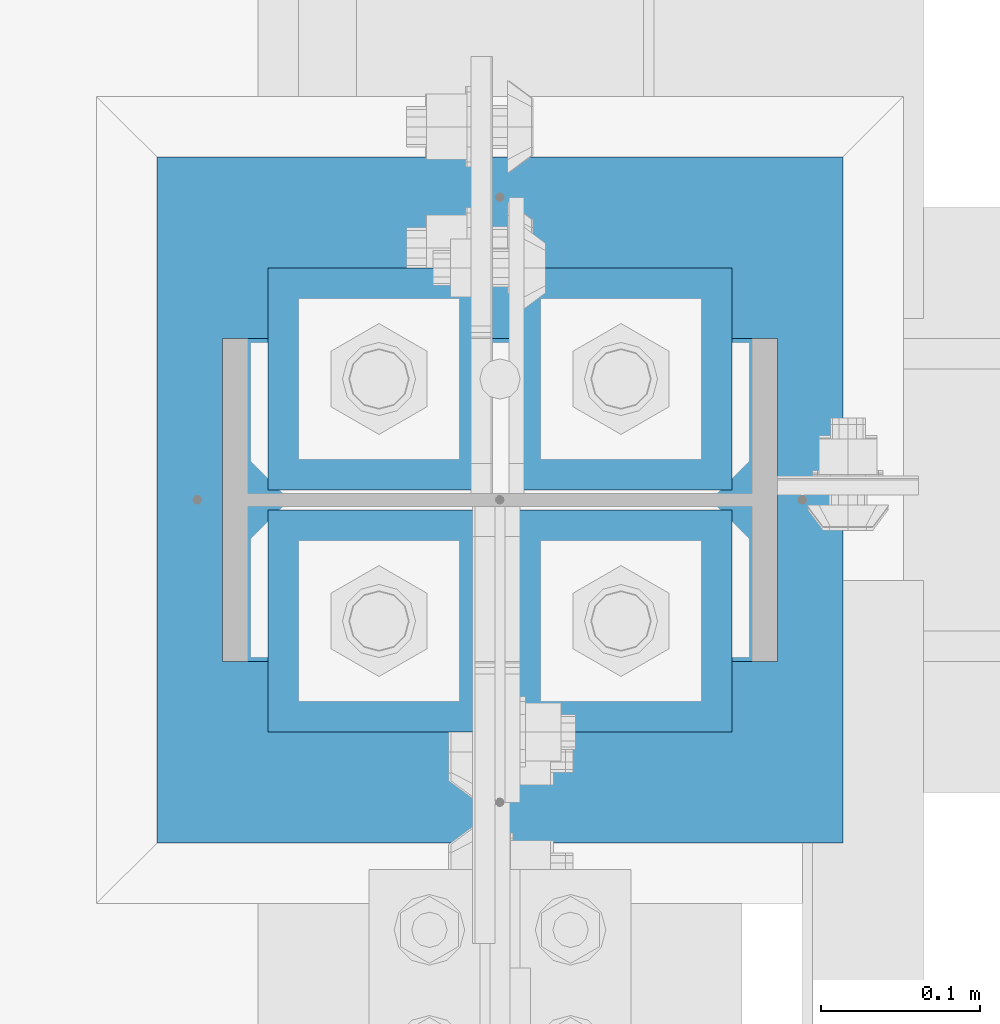
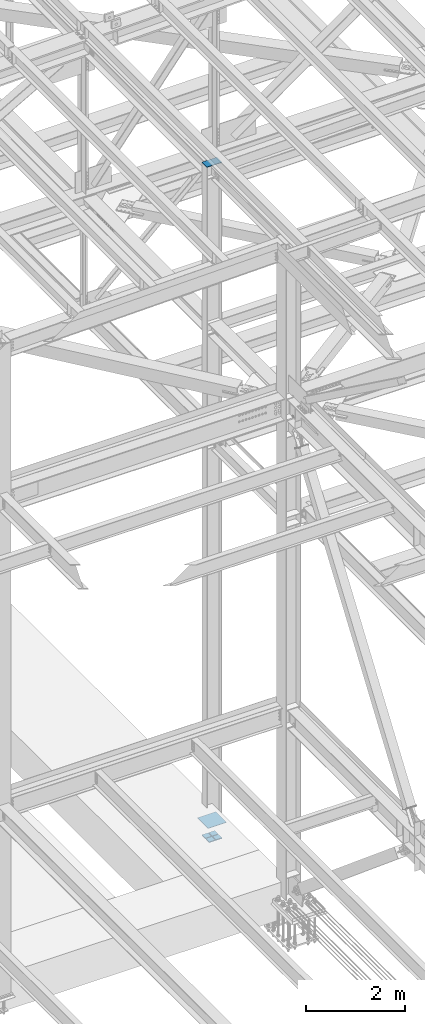
# One storey, part 2173 of 3843: 6 beams, 2 elements without a shape of their own.
"""IFC2X3 building model written with IfcOpenShell, lengths in millimetres."""

from ifc_helpers import new_model, si_unit, frame, origin_with_axes, place, context, subcontext, project, spatial, faceted_brep, material, type_object, element, aggregate, save


model = new_model("IFC2X3")

# Units and contexts
model_context = context("Model", 3, precision=1e-05, world=origin_with_axes())
body_context = subcontext(model_context, "Body", "Model", "MODEL_VIEW")
ifc_project = project(units=[si_unit("LENGTHUNIT", "METRE", prefix="MILLI"), si_unit("AREAUNIT", "SQUARE_METRE"), si_unit("VOLUMEUNIT", "CUBIC_METRE"), si_unit("MASSUNIT", "GRAM", prefix="KILO"), si_unit("TIMEUNIT", "SECOND"), si_unit("PLANEANGLEUNIT", "RADIAN"), si_unit("SOLIDANGLEUNIT", "STERADIAN"), si_unit("THERMODYNAMICTEMPERATUREUNIT", "DEGREE_CELSIUS"), si_unit("LUMINOUSINTENSITYUNIT", "LUMEN")], contexts=[model_context])

# Site, building, storey
site_placement = place(None, origin_with_axes())
site = spatial("IfcSite", under=ifc_project, at=site_placement, CompositionType="ELEMENT")
building_placement = place(site_placement, origin_with_axes())
building = spatial("IfcBuilding", under=site, at=building_placement, Name="Undefined", CompositionType="ELEMENT")
storey_placement = place(building_placement, origin_with_axes())
storey = spatial("IfcBuildingStorey", under=building, at=storey_placement, Name="Undefined", CompositionType="ELEMENT", Elevation=0.0)

# Assembly, beam
assembly_1_placement = place(storey_placement, origin_with_axes())
assembly_1 = element("IfcElementAssembly", 1, at=assembly_1_placement, inside=storey, Name="COLUMN", AssemblyPlace="NOTDEFINED", PredefinedType="RIGID_FRAME")
ifc_material = material(Name="STEEL/A572-50")
beam_type_1 = type_object("IfcBeamType", PredefinedType="NOTDEFINED")
beam_1_placement = place(assembly_1_placement, frame((77187.425, 28714.7, 46248.4455351929), z_axis=(0.0, 1.0, 0.0), x_axis=(-1.0, 0.0, 0.0)))
beam_1 = element("IfcBeam", 2, at=beam_1_placement, type_object=beam_type_1, material=ifc_material, Name="PLATE", context=body_context, shape_type="Brep", body=[
    faceted_brep([(1.74622982740402e-10, 6.35000000000582, -101.600000000195), (-1.67347025126219e-10, 6.35000000000582, 101.600000000151), (349.25, 6.34999999999854, 101.600000000006), (349.25, 6.34999999999854, -101.600000000006), (-1.67347025126219e-10, -6.35000000000582, 101.600000000151), (349.25, -6.34999999999854, 101.600000000006), (1.74622982740402e-10, -6.35000000000582, -101.600000000195), (349.25, -6.34999999999854, -101.600000000006)], [[[0, 1, 2, 3]], [[1, 4, 5, 2]], [[4, 6, 7, 5]], [[6, 0, 3, 7]], [[5, 7, 3, 2]], [[6, 4, 1, 0]]]),
])
aggregate(assembly_1, [beam_1])

# Assembly, beams
assembly_2_placement = place(storey_placement, origin_with_axes())
assembly_2 = element("IfcElementAssembly", 3, at=assembly_2_placement, inside=storey, Name="TEMPLATE", AssemblyPlace="NOTDEFINED", PredefinedType="RIGID_FRAME")
beam_type_2 = type_object("IfcBeamType", PredefinedType="NOTDEFINED")
beam_2_placement = place(assembly_2_placement, frame((77158.85, 28638.5, 29656.0875), z_axis=(0.0, 1.0, 0.0), x_axis=(-1.0, 0.0, 0.0)))
beam_2 = element("IfcBeam", 4, at=beam_2_placement, type_object=beam_type_2, material=ifc_material, context=body_context, shape_type="Brep", body=[
    faceted_brep([(0.0, 11.1124999999993, -69.8499999999985), (0.0, 11.1124999999993, 69.8499999999985), (139.699999999997, 11.1124999999993, 69.8499999999985), (139.699999999997, 11.1124999999993, -69.8499999999985), (0.0, -11.1124999999993, 69.8499999999985), (139.699999999997, -11.1124999999993, 69.8499999999985), (0.0, -11.1124999999993, -69.8499999999985), (139.699999999997, -11.1124999999993, -69.8499999999985)], [[[0, 1, 2, 3]], [[1, 4, 5, 2]], [[4, 6, 7, 5]], [[6, 0, 3, 7]], [[5, 7, 3, 2]], [[6, 4, 1, 0]]]),
])
beam_3_placement = place(assembly_2_placement, frame((77158.85, 28790.9, 29656.0875), z_axis=(0.0, 1.0, 0.0), x_axis=(-1.0, 0.0, 0.0)))
beam_3 = element("IfcBeam", 5, at=beam_3_placement, type_object=beam_type_2, material=ifc_material, context=body_context, shape_type="Brep", body=[
    faceted_brep([(0.0, 11.1124999999993, -69.8499999999985), (0.0, 11.1124999999993, 69.8499999999985), (139.699999999997, 11.1124999999993, 69.8499999999985), (139.699999999997, 11.1124999999993, -69.8499999999985), (0.0, -11.1124999999993, 69.8499999999985), (139.699999999997, -11.1124999999993, 69.8499999999985), (0.0, -11.1124999999993, -69.8499999999985), (139.699999999997, -11.1124999999993, -69.8499999999985)], [[[0, 1, 2, 3]], [[1, 4, 5, 2]], [[4, 6, 7, 5]], [[6, 0, 3, 7]], [[5, 7, 3, 2]], [[6, 4, 1, 0]]]),
])
beam_4_placement = place(assembly_2_placement, frame((77006.45, 28638.5, 29656.0875), z_axis=(0.0, 1.0, 0.0), x_axis=(-1.0, 0.0, 0.0)))
beam_4 = element("IfcBeam", 6, at=beam_4_placement, type_object=beam_type_2, material=ifc_material, context=body_context, shape_type="Brep", body=[
    faceted_brep([(0.0, 11.1124999999993, -69.8499999999985), (0.0, 11.1124999999993, 69.8499999999985), (139.699999999997, 11.1124999999993, 69.8499999999985), (139.699999999997, 11.1124999999993, -69.8499999999985), (0.0, -11.1124999999993, 69.8499999999985), (139.699999999997, -11.1124999999993, 69.8499999999985), (0.0, -11.1124999999993, -69.8499999999985), (139.699999999997, -11.1124999999993, -69.8499999999985)], [[[0, 1, 2, 3]], [[1, 4, 5, 2]], [[4, 6, 7, 5]], [[6, 0, 3, 7]], [[5, 7, 3, 2]], [[6, 4, 1, 0]]]),
])
beam_5_placement = place(assembly_2_placement, frame((77006.45, 28790.9, 29656.0875), z_axis=(0.0, 1.0, 0.0), x_axis=(-1.0, 0.0, 0.0)))
beam_5 = element("IfcBeam", 7, at=beam_5_placement, type_object=beam_type_2, material=ifc_material, context=body_context, shape_type="Brep", body=[
    faceted_brep([(0.0, 11.1124999999993, -69.8499999999985), (0.0, 11.1124999999993, 69.8499999999985), (139.699999999997, 11.1124999999993, 69.8499999999985), (139.699999999997, 11.1124999999993, -69.8499999999985), (0.0, -11.1124999999993, 69.8499999999985), (139.699999999997, -11.1124999999993, 69.8499999999985), (0.0, -11.1124999999993, -69.8499999999985), (139.699999999997, -11.1124999999993, -69.8499999999985)], [[[0, 1, 2, 3]], [[1, 4, 5, 2]], [[4, 6, 7, 5]], [[6, 0, 3, 7]], [[5, 7, 3, 2]], [[6, 4, 1, 0]]]),
])
beam_type_3 = type_object("IfcBeamType", PredefinedType="NOTDEFINED")
beam_6_placement = place(assembly_2_placement, frame((77228.7, 28714.7, 30064.075), z_axis=(0.0, -1.0, 0.0), x_axis=(-1.0, 0.0, 0.0)))
beam_6 = element("IfcBeam", 8, at=beam_6_placement, type_object=beam_type_3, material=ifc_material, Name="TEMPLATE", context=body_context, shape_type="Brep", body=[
    faceted_brep([(0.0, 3.17499999999927, -215.900000000001), (0.0, 3.17499999999927, 215.900000000001), (431.799999999988, 3.17499999999927, 215.900000000001), (431.799999999988, 3.17499999999927, -215.900000000001), (0.0, -3.17499999999927, 215.900000000001), (431.799999999988, -3.17499999999927, 215.900000000001), (0.0, -3.17499999999927, -215.900000000001), (431.799999999988, -3.17499999999927, -215.900000000001)], [[[0, 1, 2, 3]], [[1, 4, 5, 2]], [[4, 6, 7, 5]], [[6, 0, 3, 7]], [[5, 7, 3, 2]], [[6, 4, 1, 0]]]),
])
aggregate(assembly_2, [beam_2, beam_3, beam_4, beam_5, beam_6])

save(model, "model.ifc")
